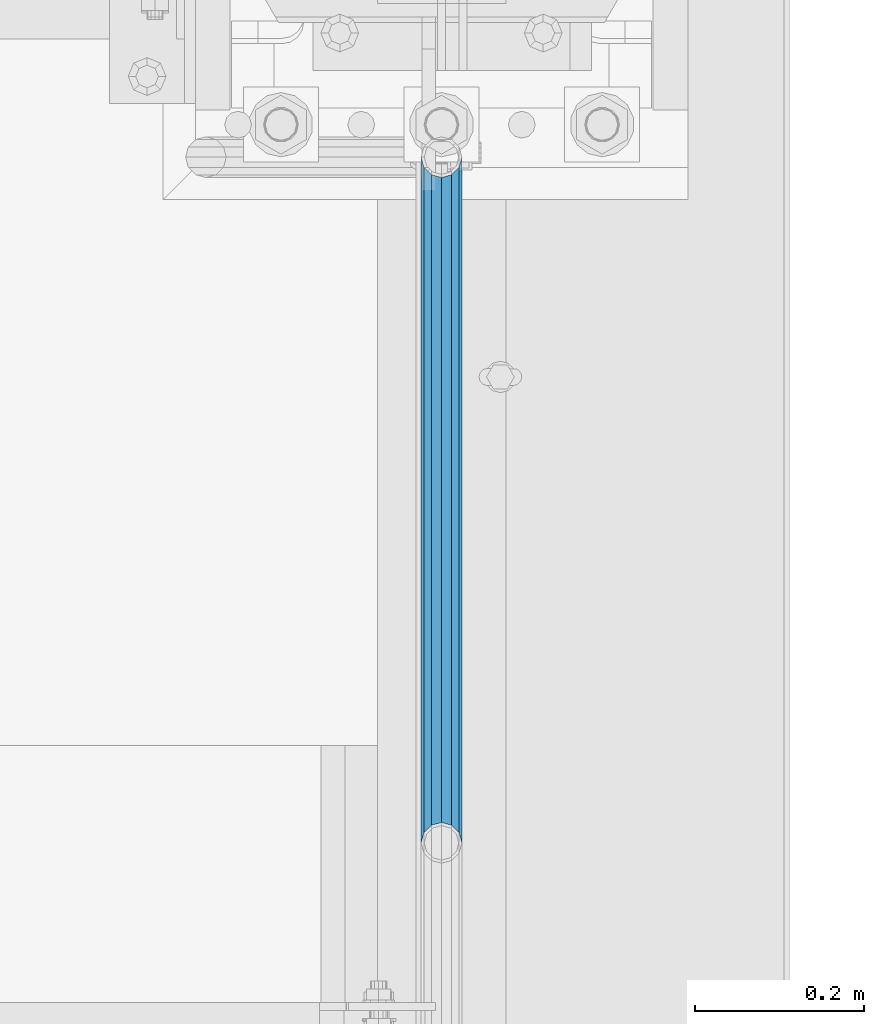
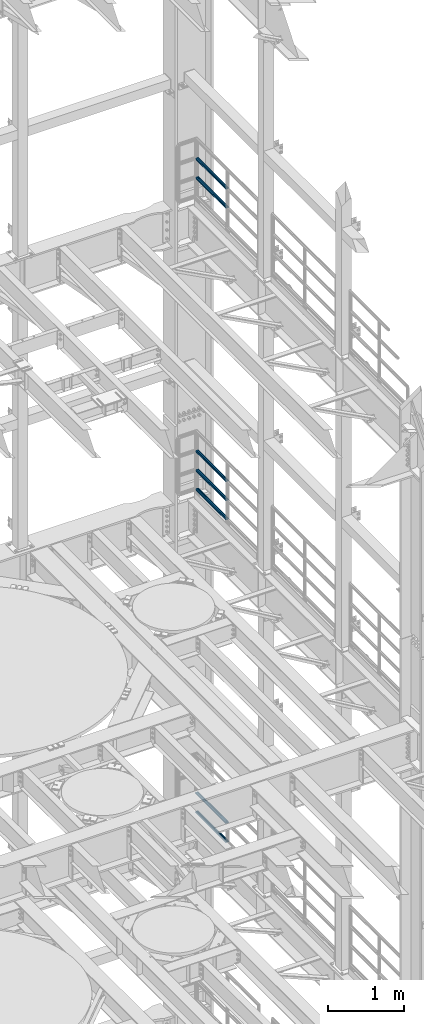
# One storey, part 1351 of 1876: 7 beams, 3 elements without a shape of their own.
"""IFC2X3 building model written with IfcOpenShell, lengths in millimetres."""

from ifc_helpers import new_model, si_unit, frame, origin_with_axes, place, context, subcontext, project, spatial, faceted_brep, material, type_object, element, aggregate, save


model = new_model("IFC2X3")

# Units and contexts
model_context = context("Model", 3, precision=1e-05, world=origin_with_axes())
body_context = subcontext(model_context, "Body", "Model", "MODEL_VIEW")
ifc_project = project(units=[si_unit("LENGTHUNIT", "METRE", prefix="MILLI"), si_unit("AREAUNIT", "SQUARE_METRE"), si_unit("VOLUMEUNIT", "CUBIC_METRE"), si_unit("MASSUNIT", "GRAM", prefix="KILO"), si_unit("TIMEUNIT", "SECOND"), si_unit("PLANEANGLEUNIT", "RADIAN"), si_unit("SOLIDANGLEUNIT", "STERADIAN"), si_unit("THERMODYNAMICTEMPERATUREUNIT", "DEGREE_CELSIUS"), si_unit("LUMINOUSINTENSITYUNIT", "LUMEN")], contexts=[model_context])

# Site, building, storey
site_placement = place(None, origin_with_axes())
site = spatial("IfcSite", under=ifc_project, at=site_placement, CompositionType="ELEMENT")
building_placement = place(site_placement, origin_with_axes())
building = spatial("IfcBuilding", under=site, at=building_placement, Name="Undefined", CompositionType="ELEMENT")
storey_placement = place(building_placement, origin_with_axes())
storey = spatial("IfcBuildingStorey", under=building, at=storey_placement, Name="Undefined", CompositionType="ELEMENT", Elevation=0.0)

# Assembly, beams
assembly_1_placement = place(storey_placement, origin_with_axes())
assembly_1 = element("IfcElementAssembly", 1, at=assembly_1_placement, inside=storey, Name="RAIL", AssemblyPlace="NOTDEFINED", PredefinedType="RIGID_FRAME")
ifc_material = material()
beam_type = type_object("IfcBeamType", Name="PIPE1-1/2SCH40", PredefinedType="NOTDEFINED")
beam_1_placement = place(assembly_1_placement, frame((7620.0, 12686.3094, 18449.925), z_axis=(0.0, 0.0, -1.0), x_axis=(0.0, 1.0, 0.0)))
beam_1 = element("IfcBeam", 2, at=beam_1_placement, type_object=beam_type, material=ifc_material, Name="RAIL", ObjectType="PIPE1-1/2SCH40", context=body_context, shape_type="Brep", body=[
    faceted_brep([(0.0, 24.1299999999992, 0.0), (12.0650000000064, 20.8971929933177, -12.0649999999987), (12.0650000000064, 20.8971929933177, 12.0649999999987), (12.0650000000064, -20.8971929933177, 12.0649999999987), (12.0650000000064, -20.8971929933177, -12.0649999999987), (0.0, -24.1299999999992, 0.0), (20.8971929933249, -12.0650000000005, 20.8971929933177), (20.8971929933249, -12.0650000000005, 15.8661214311796), (15.2545715621445, -17.7076214311801, 10.2235000000001), (12.5151929933249, -20.4470000000001, 0.0), (15.2545715621445, -17.7076214311801, -10.2235000000001), (20.8971929933249, -12.0650000000005, -15.8661214311796), (20.8971929933249, -12.0650000000005, -20.8971929933177), (24.1300000000063, 0.0, -20.4470000000001), (24.1300000000063, 0.0, -24.130000000001), (21.3906214311868, -10.2235000000001, -17.7076214311819), (21.3906214311868, 10.2235000000001, -17.7076214311819), (20.8971929933249, 12.0650000000005, -15.8661214311796), (20.8971929933249, 12.0650000000005, -20.8971929933177), (15.2545715621445, 17.7076214311801, -10.2235000000001), (12.5151929933249, 20.4470000000001, 0.0), (15.2545715621445, 17.7076214311801, 10.2235000000001), (20.8971929933249, 12.0650000000005, 15.8661214311796), (20.8971929933249, 12.0650000000005, 20.8971929933177), (21.3906214311868, 10.2235000000001, 17.7076214311819), (24.1300000000064, 0.0, 20.4470000000001), (24.1300000000064, 0.0, 24.130000000001), (21.3906214311868, -10.2235000000001, 17.7076214311819), (813.396900000002, 24.1300000000001, 0.0), (801.331900000001, 20.8971929933186, -12.0649999999987), (792.499707006684, 12.0649999999996, -20.8971929933177), (813.396900000002, -24.1300000000319, 0.0), (801.331900000001, -20.8971929933186, -12.0649999999987), (801.331900000001, -20.8971929933186, 12.0649999999987), (792.499707006684, -12.0649999999996, 20.8971929933177), (792.499707006684, -12.0649999999996, -20.8971929933177), (789.266900000001, 0.0, -24.130000000001), (792.00627856883, 10.2235000000001, -17.7076214311819), (789.266900000001, 0.0, -20.4470000000001), (792.499707006684, 12.0649999999678, -15.8661214312124), (792.499707006684, -12.0650000000314, -15.8661214311469), (792.006278568813, -10.2235000000001, -17.7076214311819), (798.142328437831, -17.7076214311801, -10.2235000000001), (800.881707006651, -20.4470000000001, 0.0), (798.142328437831, -17.7076214311801, 10.2235000000001), (792.499707006684, -12.0650000000314, 15.8661214311469), (792.006278568813, -10.2235000000001, 17.7076214311819), (789.266900000001, -9.09494701772928e-13, 20.4470000000001), (789.266900000001, -9.09494701772928e-13, 24.130000000001), (792.499707006684, 12.0649999999996, 20.8971929933177), (801.331900000001, 20.8971929933186, 12.0649999999987), (792.499707006684, 12.0649999999678, 15.8661214312124), (798.142328437896, 17.7076214311801, 10.2235000000001), (800.881707006714, 20.4470000000001, 0.0), (798.142328437896, 17.7076214311801, -10.2235000000001), (792.00627856883, 10.2235000000001, 17.7076214311819)], [[[0, 1, 2]], [[3, 4, 5]], [[6, 7, 8, 9, 10, 11, 12, 4, 3]], [[13, 14, 12, 11, 15]], [[16, 17, 18, 14, 13]], [[2, 1, 18, 17, 19, 20, 21, 22, 23]], [[23, 22, 24, 25, 26]], [[26, 25, 27, 7, 6]], [[1, 0, 28, 29]], [[18, 1, 29, 30]], [[31, 32, 33]], [[6, 3, 33, 34]], [[3, 5, 31, 33]], [[5, 4, 32, 31]], [[4, 12, 35, 32]], [[12, 14, 36, 35]], [[14, 18, 30, 36]], [[37, 38, 36, 30, 39]], [[40, 35, 36, 38, 41]], [[33, 32, 35, 40, 42, 43, 44, 45, 34]], [[34, 45, 46, 47, 48]], [[26, 6, 34, 48]], [[2, 23, 49, 50]], [[23, 26, 48, 49]], [[0, 2, 50, 28]], [[28, 50, 29]], [[49, 51, 52, 53, 54, 39, 30, 29, 50]], [[48, 47, 55, 51, 49]], [[25, 24, 55, 47]], [[55, 24, 22, 21, 52, 51]], [[21, 20, 53, 52]], [[20, 19, 54, 53]], [[19, 17, 16, 37, 39, 54]], [[16, 13, 38, 37]], [[13, 15, 41, 38]], [[41, 15, 11, 10, 42, 40]], [[10, 9, 43, 42]], [[9, 8, 44, 43]], [[8, 7, 27, 46, 45, 44]], [[27, 25, 47, 46]]]),
])
beam_2_placement = place(assembly_1_placement, frame((7620.0, 12686.3094, 18754.725), z_axis=(0.0, 0.0, -1.0), x_axis=(0.0, 1.0, 0.0)))
beam_2 = element("IfcBeam", 3, at=beam_2_placement, type_object=beam_type, material=ifc_material, Name="RAIL", ObjectType="PIPE1-1/2SCH40", context=body_context, shape_type="Brep", body=[
    faceted_brep([(0.0, 24.1299999999992, 0.0), (12.0650000000064, 20.8971929933177, -12.0649999999987), (12.0650000000064, 20.8971929933177, 12.0649999999987), (12.0650000000064, -20.8971929933177, 12.0649999999987), (12.0650000000064, -20.8971929933177, -12.0649999999987), (0.0, -24.1299999999992, 0.0), (20.8971929933249, -12.0650000000005, 20.8971929933177), (20.8971929933249, -12.0650000000005, 15.8661214311796), (15.2545715621445, -17.7076214311801, 10.2235000000001), (12.5151929933249, -20.4470000000001, 0.0), (15.2545715621445, -17.7076214311801, -10.2235000000001), (20.8971929933249, -12.0650000000005, -15.8661214311796), (20.8971929933249, -12.0650000000005, -20.8971929933177), (24.1300000000063, 0.0, -20.4470000000001), (24.1300000000063, 0.0, -24.130000000001), (21.3906214311868, -10.2235000000001, -17.7076214311819), (21.3906214311868, 10.2235000000001, -17.7076214311819), (20.8971929933249, 12.0650000000005, -15.8661214311796), (20.8971929933249, 12.0650000000005, -20.8971929933177), (15.2545715621445, 17.7076214311801, -10.2235000000001), (12.5151929933249, 20.4470000000001, 0.0), (15.2545715621445, 17.7076214311801, 10.2235000000001), (20.8971929933249, 12.0650000000005, 15.8661214311796), (20.8971929933249, 12.0650000000005, 20.8971929933177), (21.3906214311868, 10.2235000000001, 17.7076214311819), (24.1300000000064, 0.0, 20.4470000000001), (24.1300000000064, 0.0, 24.130000000001), (21.3906214311868, -10.2235000000001, 17.7076214311819), (813.396900000002, 24.1300000000001, 0.0), (801.331900000001, 20.8971929933186, -12.0649999999987), (792.499707006684, 12.0649999999996, -20.8971929933177), (813.396900000002, -24.1300000000319, 0.0), (801.331900000001, -20.8971929933186, -12.0649999999987), (801.331900000001, -20.8971929933186, 12.0649999999987), (792.499707006684, -12.0649999999996, 20.8971929933177), (792.499707006684, -12.0649999999996, -20.8971929933177), (789.266900000001, 0.0, -24.130000000001), (792.00627856883, 10.2235000000001, -17.7076214311819), (789.266900000001, 0.0, -20.4470000000001), (792.499707006684, 12.0649999999678, -15.8661214312124), (792.499707006684, -12.0650000000314, -15.8661214311469), (792.006278568813, -10.2235000000001, -17.7076214311819), (798.142328437831, -17.7076214311801, -10.2235000000001), (800.881707006651, -20.4470000000001, 0.0), (798.142328437831, -17.7076214311801, 10.2235000000001), (792.499707006684, -12.0650000000314, 15.8661214311469), (792.006278568813, -10.2235000000001, 17.7076214311819), (789.266900000001, -9.09494701772928e-13, 20.4470000000001), (789.266900000001, -9.09494701772928e-13, 24.130000000001), (792.499707006684, 12.0649999999996, 20.8971929933177), (801.331900000001, 20.8971929933186, 12.0649999999987), (792.499707006684, 12.0649999999678, 15.8661214312124), (798.142328437896, 17.7076214311801, 10.2235000000001), (800.881707006714, 20.4470000000001, 0.0), (798.142328437896, 17.7076214311801, -10.2235000000001), (792.00627856883, 10.2235000000001, 17.7076214311819)], [[[0, 1, 2]], [[3, 4, 5]], [[6, 7, 8, 9, 10, 11, 12, 4, 3]], [[13, 14, 12, 11, 15]], [[16, 17, 18, 14, 13]], [[2, 1, 18, 17, 19, 20, 21, 22, 23]], [[23, 22, 24, 25, 26]], [[26, 25, 27, 7, 6]], [[1, 0, 28, 29]], [[18, 1, 29, 30]], [[31, 32, 33]], [[6, 3, 33, 34]], [[3, 5, 31, 33]], [[5, 4, 32, 31]], [[4, 12, 35, 32]], [[12, 14, 36, 35]], [[14, 18, 30, 36]], [[37, 38, 36, 30, 39]], [[40, 35, 36, 38, 41]], [[33, 32, 35, 40, 42, 43, 44, 45, 34]], [[34, 45, 46, 47, 48]], [[26, 6, 34, 48]], [[2, 23, 49, 50]], [[23, 26, 48, 49]], [[0, 2, 50, 28]], [[28, 50, 29]], [[49, 51, 52, 53, 54, 39, 30, 29, 50]], [[48, 47, 55, 51, 49]], [[25, 24, 55, 47]], [[55, 24, 22, 21, 52, 51]], [[21, 20, 53, 52]], [[20, 19, 54, 53]], [[19, 17, 16, 37, 39, 54]], [[16, 13, 38, 37]], [[13, 15, 41, 38]], [[41, 15, 11, 10, 42, 40]], [[10, 9, 43, 42]], [[9, 8, 44, 43]], [[8, 7, 27, 46, 45, 44]], [[27, 25, 47, 46]]]),
])
aggregate(assembly_1, [beam_1, beam_2])

assembly_2_placement = place(storey_placement, origin_with_axes())
assembly_2 = element("IfcElementAssembly", 4, at=assembly_2_placement, inside=storey, Name="RAIL", AssemblyPlace="NOTDEFINED", PredefinedType="RIGID_FRAME")
beam_3_placement = place(assembly_2_placement, frame((7620.00000000002, 13499.7063, 13471.525), z_axis=(0.0, 0.0, 1.0), x_axis=(0.0, -1.0, 0.0)))
beam_3 = element("IfcBeam", 5, at=beam_3_placement, type_object=beam_type, material=ifc_material, Name="RAIL", ObjectType="PIPE1-1/2SCH40", context=body_context, shape_type="Brep", body=[
    faceted_brep([(792.499707006684, -12.0649999999996, 20.8971929933177), (792.499707006684, -12.0650000000314, 15.8661214311469), (792.006278568813, -10.2235000000001, 17.7076214311819), (789.266900000001, -9.09494701772928e-13, 20.4470000000001), (789.266900000001, -9.09494701772928e-13, 24.130000000001), (792.00627856883, 10.2235000000001, 17.7076214311819), (792.499707006684, 12.0649999999678, 15.8661214312124), (792.499707006684, 12.0649999999996, 20.8971929933177), (813.396900000002, 24.1300000000001, 0.0), (801.331900000001, 20.8971929933186, 12.0649999999987), (801.331900000001, 20.8971929933186, -12.0649999999987), (798.142328437896, 17.7076214311801, 10.2235000000001), (800.881707006714, 20.4470000000001, 0.0), (798.142328437896, 17.7076214311801, -10.2235000000001), (792.499707006684, 12.0649999999678, -15.8661214312124), (792.499707006684, 12.0649999999996, -20.8971929933177), (792.00627856883, 10.2235000000001, -17.7076214311819), (789.266900000001, 0.0, -20.4470000000001), (789.266900000001, 0.0, -24.130000000001), (792.499707006684, -12.0650000000314, -15.8661214311469), (792.499707006684, -12.0649999999996, -20.8971929933177), (792.006278568813, -10.2235000000001, -17.7076214311819), (813.396900000002, -24.1300000000319, 0.0), (801.331900000001, -20.8971929933186, -12.0649999999987), (801.331900000001, -20.8971929933186, 12.0649999999987), (798.142328437831, -17.7076214311801, -10.2235000000001), (800.881707006651, -20.4470000000001, 0.0), (798.142328437831, -17.7076214311801, 10.2235000000001), (12.0650000000064, -20.8971929933177, -12.0649999999987), (20.8971929933249, -12.0650000000005, -20.8971929933177), (0.0, 24.1299999999992, 0.0), (12.0650000000064, 20.8971929933177, -12.0649999999987), (12.0650000000064, 20.8971929933177, 12.0649999999987), (20.8971929933249, 12.0650000000005, 20.8971929933177), (24.1300000000064, 0.0, 24.130000000001), (20.8971929933249, 12.0650000000005, -20.8971929933177), (24.1300000000063, 0.0, -24.130000000001), (24.1300000000063, 0.0, -20.4470000000001), (20.8971929933249, -12.0650000000005, -15.8661214311796), (21.3906214311868, -10.2235000000001, -17.7076214311819), (21.3906214311868, 10.2235000000001, -17.7076214311819), (20.8971929933249, 12.0650000000005, -15.8661214311796), (15.2545715621445, 17.7076214311801, -10.2235000000001), (12.5151929933249, 20.4470000000001, 0.0), (15.2545715621445, 17.7076214311801, 10.2235000000001), (20.8971929933249, 12.0650000000005, 15.8661214311796), (21.3906214311868, 10.2235000000001, 17.7076214311819), (24.1300000000064, 0.0, 20.4470000000001), (21.3906214311868, -10.2235000000001, 17.7076214311819), (20.8971929933249, -12.0650000000005, 15.8661214311796), (20.8971929933249, -12.0650000000005, 20.8971929933177), (12.0650000000064, -20.8971929933177, 12.0649999999987), (0.0, -24.1299999999992, 0.0), (15.2545715621445, -17.7076214311801, 10.2235000000001), (12.5151929933249, -20.4470000000001, 0.0), (15.2545715621445, -17.7076214311801, -10.2235000000001)], [[[0, 1, 2, 3, 4]], [[4, 3, 5, 6, 7]], [[8, 9, 10]], [[7, 6, 11, 12, 13, 14, 15, 10, 9]], [[16, 17, 18, 15, 14]], [[19, 20, 18, 17, 21]], [[22, 23, 24]], [[24, 23, 20, 19, 25, 26, 27, 1, 0]], [[28, 29, 20, 23]], [[30, 31, 32]], [[33, 34, 4, 7]], [[32, 33, 7, 9]], [[30, 32, 9, 8]], [[31, 30, 8, 10]], [[35, 31, 10, 15]], [[36, 35, 15, 18]], [[29, 36, 18, 20]], [[37, 36, 29, 38, 39]], [[40, 41, 35, 36, 37]], [[32, 31, 35, 41, 42, 43, 44, 45, 33]], [[33, 45, 46, 47, 34]], [[34, 47, 48, 49, 50]], [[34, 50, 0, 4]], [[50, 51, 24, 0]], [[51, 52, 22, 24]], [[52, 28, 23, 22]], [[51, 28, 52]], [[50, 49, 53, 54, 55, 38, 29, 28, 51]], [[55, 54, 26, 25]], [[21, 39, 38, 55, 25, 19]], [[37, 39, 21, 17]], [[40, 37, 17, 16]], [[42, 41, 40, 16, 14, 13]], [[43, 42, 13, 12]], [[44, 43, 12, 11]], [[5, 46, 45, 44, 11, 6]], [[47, 46, 5, 3]], [[48, 47, 3, 2]], [[53, 49, 48, 2, 1, 27]], [[54, 53, 27, 26]]]),
])
beam_4_placement = place(assembly_2_placement, frame((7620.0, 12686.3094, 13776.325), z_axis=(0.0, 0.0, -1.0), x_axis=(0.0, 1.0, 0.0)))
beam_4 = element("IfcBeam", 6, at=beam_4_placement, type_object=beam_type, material=ifc_material, Name="RAIL", ObjectType="PIPE1-1/2SCH40", context=body_context, shape_type="Brep", body=[
    faceted_brep([(0.0, 24.1299999999992, 0.0), (12.0650000000064, 20.8971929933177, -12.0649999999987), (12.0650000000064, 20.8971929933177, 12.0649999999987), (12.0650000000064, -20.8971929933177, 12.0649999999987), (12.0650000000064, -20.8971929933177, -12.0649999999987), (0.0, -24.1299999999992, 0.0), (20.8971929933249, -12.0650000000005, 20.8971929933177), (20.8971929933249, -12.0650000000005, 15.8661214311796), (15.2545715621445, -17.7076214311801, 10.2235000000001), (12.5151929933249, -20.4470000000001, 0.0), (15.2545715621445, -17.7076214311801, -10.2235000000001), (20.8971929933249, -12.0650000000005, -15.8661214311796), (20.8971929933249, -12.0650000000005, -20.8971929933177), (24.1300000000063, 0.0, -20.4470000000001), (24.1300000000063, 0.0, -24.130000000001), (21.3906214311868, -10.2235000000001, -17.7076214311819), (21.3906214311868, 10.2235000000001, -17.7076214311819), (20.8971929933249, 12.0650000000005, -15.8661214311796), (20.8971929933249, 12.0650000000005, -20.8971929933177), (15.2545715621445, 17.7076214311801, -10.2235000000001), (12.5151929933249, 20.4470000000001, 0.0), (15.2545715621445, 17.7076214311801, 10.2235000000001), (20.8971929933249, 12.0650000000005, 15.8661214311796), (20.8971929933249, 12.0650000000005, 20.8971929933177), (21.3906214311868, 10.2235000000001, 17.7076214311819), (24.1300000000064, 0.0, 20.4470000000001), (24.1300000000064, 0.0, 24.130000000001), (21.3906214311868, -10.2235000000001, 17.7076214311819), (813.396900000002, 24.1300000000001, 0.0), (801.331900000001, 20.8971929933186, -12.0649999999987), (792.499707006684, 12.0649999999996, -20.8971929933177), (813.396900000002, -24.1300000000319, 0.0), (801.331900000001, -20.8971929933186, -12.0649999999987), (801.331900000001, -20.8971929933186, 12.0649999999987), (792.499707006684, -12.0649999999996, 20.8971929933177), (792.499707006684, -12.0649999999996, -20.8971929933177), (789.266900000001, 0.0, -24.130000000001), (792.00627856883, 10.2235000000001, -17.7076214311819), (789.266900000001, 0.0, -20.4470000000001), (792.499707006684, 12.0649999999678, -15.8661214312124), (792.499707006684, -12.0650000000314, -15.8661214311469), (792.006278568813, -10.2235000000001, -17.7076214311819), (798.142328437831, -17.7076214311801, -10.2235000000001), (800.881707006651, -20.4470000000001, 0.0), (798.142328437831, -17.7076214311801, 10.2235000000001), (792.499707006684, -12.0650000000314, 15.8661214311469), (792.006278568813, -10.2235000000001, 17.7076214311819), (789.266900000001, -9.09494701772928e-13, 20.4470000000001), (789.266900000001, -9.09494701772928e-13, 24.130000000001), (792.499707006684, 12.0649999999996, 20.8971929933177), (801.331900000001, 20.8971929933186, 12.0649999999987), (792.499707006684, 12.0649999999678, 15.8661214312124), (798.142328437896, 17.7076214311801, 10.2235000000001), (800.881707006714, 20.4470000000001, 0.0), (798.142328437896, 17.7076214311801, -10.2235000000001), (792.00627856883, 10.2235000000001, 17.7076214311819)], [[[0, 1, 2]], [[3, 4, 5]], [[6, 7, 8, 9, 10, 11, 12, 4, 3]], [[13, 14, 12, 11, 15]], [[16, 17, 18, 14, 13]], [[2, 1, 18, 17, 19, 20, 21, 22, 23]], [[23, 22, 24, 25, 26]], [[26, 25, 27, 7, 6]], [[1, 0, 28, 29]], [[18, 1, 29, 30]], [[31, 32, 33]], [[6, 3, 33, 34]], [[3, 5, 31, 33]], [[5, 4, 32, 31]], [[4, 12, 35, 32]], [[12, 14, 36, 35]], [[14, 18, 30, 36]], [[37, 38, 36, 30, 39]], [[40, 35, 36, 38, 41]], [[33, 32, 35, 40, 42, 43, 44, 45, 34]], [[34, 45, 46, 47, 48]], [[26, 6, 34, 48]], [[2, 23, 49, 50]], [[23, 26, 48, 49]], [[0, 2, 50, 28]], [[28, 50, 29]], [[49, 51, 52, 53, 54, 39, 30, 29, 50]], [[48, 47, 55, 51, 49]], [[25, 24, 55, 47]], [[55, 24, 22, 21, 52, 51]], [[21, 20, 53, 52]], [[20, 19, 54, 53]], [[19, 17, 16, 37, 39, 54]], [[16, 13, 38, 37]], [[13, 15, 41, 38]], [[41, 15, 11, 10, 42, 40]], [[10, 9, 43, 42]], [[9, 8, 44, 43]], [[8, 7, 27, 46, 45, 44]], [[27, 25, 47, 46]]]),
])
beam_5_placement = place(assembly_2_placement, frame((7620.0, 12686.3094, 14081.125), z_axis=(0.0, 0.0, -1.0), x_axis=(0.0, 1.0, 0.0)))
beam_5 = element("IfcBeam", 7, at=beam_5_placement, type_object=beam_type, material=ifc_material, Name="RAIL", ObjectType="PIPE1-1/2SCH40", context=body_context, shape_type="Brep", body=[
    faceted_brep([(0.0, 24.1299999999992, 0.0), (12.0650000000064, 20.8971929933177, -12.0649999999987), (12.0650000000064, 20.8971929933177, 12.0649999999987), (12.0650000000064, -20.8971929933177, 12.0649999999987), (12.0650000000064, -20.8971929933177, -12.0649999999987), (0.0, -24.1299999999992, 0.0), (20.8971929933249, -12.0650000000005, 20.8971929933177), (20.8971929933249, -12.0650000000005, 15.8661214311796), (15.2545715621445, -17.7076214311801, 10.2235000000001), (12.5151929933249, -20.4470000000001, 0.0), (15.2545715621445, -17.7076214311801, -10.2235000000001), (20.8971929933249, -12.0650000000005, -15.8661214311796), (20.8971929933249, -12.0650000000005, -20.8971929933177), (24.1300000000063, 0.0, -20.4470000000001), (24.1300000000063, 0.0, -24.130000000001), (21.3906214311868, -10.2235000000001, -17.7076214311819), (21.3906214311868, 10.2235000000001, -17.7076214311819), (20.8971929933249, 12.0650000000005, -15.8661214311796), (20.8971929933249, 12.0650000000005, -20.8971929933177), (15.2545715621445, 17.7076214311801, -10.2235000000001), (12.5151929933249, 20.4470000000001, 0.0), (15.2545715621445, 17.7076214311801, 10.2235000000001), (20.8971929933249, 12.0650000000005, 15.8661214311796), (20.8971929933249, 12.0650000000005, 20.8971929933177), (21.3906214311868, 10.2235000000001, 17.7076214311819), (24.1300000000064, 0.0, 20.4470000000001), (24.1300000000064, 0.0, 24.130000000001), (21.3906214311868, -10.2235000000001, 17.7076214311819), (813.396900000002, 24.1300000000001, 0.0), (801.331900000001, 20.8971929933186, -12.0649999999987), (792.499707006684, 12.0649999999996, -20.8971929933177), (813.396900000002, -24.1300000000319, 0.0), (801.331900000001, -20.8971929933186, -12.0649999999987), (801.331900000001, -20.8971929933186, 12.0649999999987), (792.499707006684, -12.0649999999996, 20.8971929933177), (792.499707006684, -12.0649999999996, -20.8971929933177), (789.266900000001, 0.0, -24.130000000001), (792.00627856883, 10.2235000000001, -17.7076214311819), (789.266900000001, 0.0, -20.4470000000001), (792.499707006684, 12.0649999999678, -15.8661214312124), (792.499707006684, -12.0650000000314, -15.8661214311469), (792.006278568813, -10.2235000000001, -17.7076214311819), (798.142328437831, -17.7076214311801, -10.2235000000001), (800.881707006651, -20.4470000000001, 0.0), (798.142328437831, -17.7076214311801, 10.2235000000001), (792.499707006684, -12.0650000000314, 15.8661214311469), (792.006278568813, -10.2235000000001, 17.7076214311819), (789.266900000001, -9.09494701772928e-13, 20.4470000000001), (789.266900000001, -9.09494701772928e-13, 24.130000000001), (792.499707006684, 12.0649999999996, 20.8971929933177), (801.331900000001, 20.8971929933186, 12.0649999999987), (792.499707006684, 12.0649999999678, 15.8661214312124), (798.142328437896, 17.7076214311801, 10.2235000000001), (800.881707006714, 20.4470000000001, 0.0), (798.142328437896, 17.7076214311801, -10.2235000000001), (792.00627856883, 10.2235000000001, 17.7076214311819)], [[[0, 1, 2]], [[3, 4, 5]], [[6, 7, 8, 9, 10, 11, 12, 4, 3]], [[13, 14, 12, 11, 15]], [[16, 17, 18, 14, 13]], [[2, 1, 18, 17, 19, 20, 21, 22, 23]], [[23, 22, 24, 25, 26]], [[26, 25, 27, 7, 6]], [[1, 0, 28, 29]], [[18, 1, 29, 30]], [[31, 32, 33]], [[6, 3, 33, 34]], [[3, 5, 31, 33]], [[5, 4, 32, 31]], [[4, 12, 35, 32]], [[12, 14, 36, 35]], [[14, 18, 30, 36]], [[37, 38, 36, 30, 39]], [[40, 35, 36, 38, 41]], [[33, 32, 35, 40, 42, 43, 44, 45, 34]], [[34, 45, 46, 47, 48]], [[26, 6, 34, 48]], [[2, 23, 49, 50]], [[23, 26, 48, 49]], [[0, 2, 50, 28]], [[28, 50, 29]], [[49, 51, 52, 53, 54, 39, 30, 29, 50]], [[48, 47, 55, 51, 49]], [[25, 24, 55, 47]], [[55, 24, 22, 21, 52, 51]], [[21, 20, 53, 52]], [[20, 19, 54, 53]], [[19, 17, 16, 37, 39, 54]], [[16, 13, 38, 37]], [[13, 15, 41, 38]], [[41, 15, 11, 10, 42, 40]], [[10, 9, 43, 42]], [[9, 8, 44, 43]], [[8, 7, 27, 46, 45, 44]], [[27, 25, 47, 46]]]),
])
aggregate(assembly_2, [beam_3, beam_4, beam_5])

assembly_3_placement = place(storey_placement, origin_with_axes())
assembly_3 = element("IfcElementAssembly", 8, at=assembly_3_placement, inside=storey, Name="RAIL", AssemblyPlace="NOTDEFINED", PredefinedType="RIGID_FRAME")
beam_6_placement = place(assembly_3_placement, frame((7620.00000000002, 13499.7063, 8315.325), z_axis=(0.0, 0.0, 1.0), x_axis=(0.0, -1.0, 0.0)))
beam_6 = element("IfcBeam", 9, at=beam_6_placement, type_object=beam_type, material=ifc_material, Name="RAIL", ObjectType="PIPE1-1/2SCH40", context=body_context, shape_type="Brep", body=[
    faceted_brep([(792.499707006684, -12.0649999999996, 20.8971929933177), (792.499707006684, -12.0650000000314, 15.8661214311469), (792.006278568813, -10.2235000000001, 17.7076214311819), (789.266900000001, -9.09494701772928e-13, 20.4470000000001), (789.266900000001, -9.09494701772928e-13, 24.130000000001), (792.00627856883, 10.2235000000001, 17.7076214311819), (792.499707006684, 12.0649999999678, 15.8661214312124), (792.499707006684, 12.0649999999996, 20.8971929933177), (813.396900000002, 24.1300000000001, 0.0), (801.331900000001, 20.8971929933186, 12.0649999999987), (801.331900000001, 20.8971929933186, -12.0649999999987), (798.142328437896, 17.7076214311801, 10.2235000000001), (800.881707006714, 20.4470000000001, 0.0), (798.142328437896, 17.7076214311801, -10.2235000000001), (792.499707006684, 12.0649999999678, -15.8661214312124), (792.499707006684, 12.0649999999996, -20.8971929933177), (792.00627856883, 10.2235000000001, -17.7076214311819), (789.266900000001, 0.0, -20.4470000000001), (789.266900000001, 0.0, -24.130000000001), (792.499707006684, -12.0650000000314, -15.8661214311469), (792.499707006684, -12.0649999999996, -20.8971929933177), (792.006278568813, -10.2235000000001, -17.7076214311819), (813.396900000002, -24.1300000000319, 0.0), (801.331900000001, -20.8971929933186, -12.0649999999987), (801.331900000001, -20.8971929933186, 12.0649999999987), (798.142328437831, -17.7076214311801, -10.2235000000001), (800.881707006651, -20.4470000000001, 0.0), (798.142328437831, -17.7076214311801, 10.2235000000001), (12.0650000000064, -20.8971929933177, -12.0649999999987), (20.8971929933249, -12.0650000000005, -20.8971929933177), (0.0, 24.1299999999992, 0.0), (12.0650000000064, 20.8971929933177, -12.0649999999987), (12.0650000000064, 20.8971929933177, 12.0649999999987), (20.8971929933249, 12.0650000000005, 20.8971929933177), (24.1300000000064, 0.0, 24.130000000001), (20.8971929933249, 12.0650000000005, -20.8971929933177), (24.1300000000063, 0.0, -24.130000000001), (24.1300000000063, 0.0, -20.4470000000001), (20.8971929933249, -12.0650000000005, -15.8661214311796), (21.3906214311868, -10.2235000000001, -17.7076214311819), (21.3906214311868, 10.2235000000001, -17.7076214311819), (20.8971929933249, 12.0650000000005, -15.8661214311796), (15.2545715621445, 17.7076214311801, -10.2235000000001), (12.5151929933249, 20.4470000000001, 0.0), (15.2545715621445, 17.7076214311801, 10.2235000000001), (20.8971929933249, 12.0650000000005, 15.8661214311796), (21.3906214311868, 10.2235000000001, 17.7076214311819), (24.1300000000064, 0.0, 20.4470000000001), (21.3906214311868, -10.2235000000001, 17.7076214311819), (20.8971929933249, -12.0650000000005, 15.8661214311796), (20.8971929933249, -12.0650000000005, 20.8971929933177), (12.0650000000064, -20.8971929933177, 12.0649999999987), (0.0, -24.1299999999992, 0.0), (15.2545715621445, -17.7076214311801, 10.2235000000001), (12.5151929933249, -20.4470000000001, 0.0), (15.2545715621445, -17.7076214311801, -10.2235000000001)], [[[0, 1, 2, 3, 4]], [[4, 3, 5, 6, 7]], [[8, 9, 10]], [[7, 6, 11, 12, 13, 14, 15, 10, 9]], [[16, 17, 18, 15, 14]], [[19, 20, 18, 17, 21]], [[22, 23, 24]], [[24, 23, 20, 19, 25, 26, 27, 1, 0]], [[28, 29, 20, 23]], [[30, 31, 32]], [[33, 34, 4, 7]], [[32, 33, 7, 9]], [[30, 32, 9, 8]], [[31, 30, 8, 10]], [[35, 31, 10, 15]], [[36, 35, 15, 18]], [[29, 36, 18, 20]], [[37, 36, 29, 38, 39]], [[40, 41, 35, 36, 37]], [[32, 31, 35, 41, 42, 43, 44, 45, 33]], [[33, 45, 46, 47, 34]], [[34, 47, 48, 49, 50]], [[34, 50, 0, 4]], [[50, 51, 24, 0]], [[51, 52, 22, 24]], [[52, 28, 23, 22]], [[51, 28, 52]], [[50, 49, 53, 54, 55, 38, 29, 28, 51]], [[55, 54, 26, 25]], [[21, 39, 38, 55, 25, 19]], [[37, 39, 21, 17]], [[40, 37, 17, 16]], [[42, 41, 40, 16, 14, 13]], [[43, 42, 13, 12]], [[44, 43, 12, 11]], [[5, 46, 45, 44, 11, 6]], [[47, 46, 5, 3]], [[48, 47, 3, 2]], [[53, 49, 48, 2, 1, 27]], [[54, 53, 27, 26]]]),
])
beam_7_placement = place(assembly_3_placement, frame((7620.0, 12686.3094, 8620.125), z_axis=(0.0, 0.0, -1.0), x_axis=(0.0, 1.0, 0.0)))
beam_7 = element("IfcBeam", 10, at=beam_7_placement, type_object=beam_type, material=ifc_material, Name="RAIL", ObjectType="PIPE1-1/2SCH40", context=body_context, shape_type="Brep", body=[
    faceted_brep([(0.0, 24.1299999999992, 0.0), (12.0650000000064, 20.8971929933177, -12.0649999999987), (12.0650000000064, 20.8971929933177, 12.0649999999987), (12.0650000000064, -20.8971929933177, 12.0649999999987), (12.0650000000064, -20.8971929933177, -12.0649999999987), (0.0, -24.1299999999992, 0.0), (20.8971929933249, -12.0650000000005, 20.8971929933177), (20.8971929933249, -12.0650000000005, 15.8661214311796), (15.2545715621445, -17.7076214311801, 10.2235000000001), (12.5151929933249, -20.4470000000001, 0.0), (15.2545715621445, -17.7076214311801, -10.2235000000001), (20.8971929933249, -12.0650000000005, -15.8661214311796), (20.8971929933249, -12.0650000000005, -20.8971929933177), (24.1300000000063, 0.0, -20.4470000000001), (24.1300000000063, 0.0, -24.130000000001), (21.3906214311868, -10.2235000000001, -17.7076214311819), (21.3906214311868, 10.2235000000001, -17.7076214311819), (20.8971929933249, 12.0650000000005, -15.8661214311796), (20.8971929933249, 12.0650000000005, -20.8971929933177), (15.2545715621445, 17.7076214311801, -10.2235000000001), (12.5151929933249, 20.4470000000001, 0.0), (15.2545715621445, 17.7076214311801, 10.2235000000001), (20.8971929933249, 12.0650000000005, 15.8661214311796), (20.8971929933249, 12.0650000000005, 20.8971929933177), (21.3906214311868, 10.2235000000001, 17.7076214311819), (24.1300000000064, 0.0, 20.4470000000001), (24.1300000000064, 0.0, 24.130000000001), (21.3906214311868, -10.2235000000001, 17.7076214311819), (813.396900000002, 24.1300000000001, 0.0), (801.331900000001, 20.8971929933186, -12.0649999999987), (792.499707006684, 12.0649999999996, -20.8971929933177), (813.396900000002, -24.1300000000319, 0.0), (801.331900000001, -20.8971929933186, -12.0649999999987), (801.331900000001, -20.8971929933186, 12.0649999999987), (792.499707006684, -12.0649999999996, 20.8971929933177), (792.499707006684, -12.0649999999996, -20.8971929933177), (789.266900000001, 0.0, -24.130000000001), (792.00627856883, 10.2235000000001, -17.7076214311819), (789.266900000001, 0.0, -20.4470000000001), (792.499707006684, 12.0649999999678, -15.8661214312124), (792.499707006684, -12.0650000000314, -15.8661214311469), (792.006278568813, -10.2235000000001, -17.7076214311819), (798.142328437831, -17.7076214311801, -10.2235000000001), (800.881707006651, -20.4470000000001, 0.0), (798.142328437831, -17.7076214311801, 10.2235000000001), (792.499707006684, -12.0650000000314, 15.8661214311469), (792.006278568813, -10.2235000000001, 17.7076214311819), (789.266900000001, -9.09494701772928e-13, 20.4470000000001), (789.266900000001, -9.09494701772928e-13, 24.130000000001), (792.499707006684, 12.0649999999996, 20.8971929933177), (801.331900000001, 20.8971929933186, 12.0649999999987), (792.499707006684, 12.0649999999678, 15.8661214312124), (798.142328437896, 17.7076214311801, 10.2235000000001), (800.881707006714, 20.4470000000001, 0.0), (798.142328437896, 17.7076214311801, -10.2235000000001), (792.00627856883, 10.2235000000001, 17.7076214311819)], [[[0, 1, 2]], [[3, 4, 5]], [[6, 7, 8, 9, 10, 11, 12, 4, 3]], [[13, 14, 12, 11, 15]], [[16, 17, 18, 14, 13]], [[2, 1, 18, 17, 19, 20, 21, 22, 23]], [[23, 22, 24, 25, 26]], [[26, 25, 27, 7, 6]], [[1, 0, 28, 29]], [[18, 1, 29, 30]], [[31, 32, 33]], [[6, 3, 33, 34]], [[3, 5, 31, 33]], [[5, 4, 32, 31]], [[4, 12, 35, 32]], [[12, 14, 36, 35]], [[14, 18, 30, 36]], [[37, 38, 36, 30, 39]], [[40, 35, 36, 38, 41]], [[33, 32, 35, 40, 42, 43, 44, 45, 34]], [[34, 45, 46, 47, 48]], [[26, 6, 34, 48]], [[2, 23, 49, 50]], [[23, 26, 48, 49]], [[0, 2, 50, 28]], [[28, 50, 29]], [[49, 51, 52, 53, 54, 39, 30, 29, 50]], [[48, 47, 55, 51, 49]], [[25, 24, 55, 47]], [[55, 24, 22, 21, 52, 51]], [[21, 20, 53, 52]], [[20, 19, 54, 53]], [[19, 17, 16, 37, 39, 54]], [[16, 13, 38, 37]], [[13, 15, 41, 38]], [[41, 15, 11, 10, 42, 40]], [[10, 9, 43, 42]], [[9, 8, 44, 43]], [[8, 7, 27, 46, 45, 44]], [[27, 25, 47, 46]]]),
])
aggregate(assembly_3, [beam_6, beam_7])

save(model, "model.ifc")
